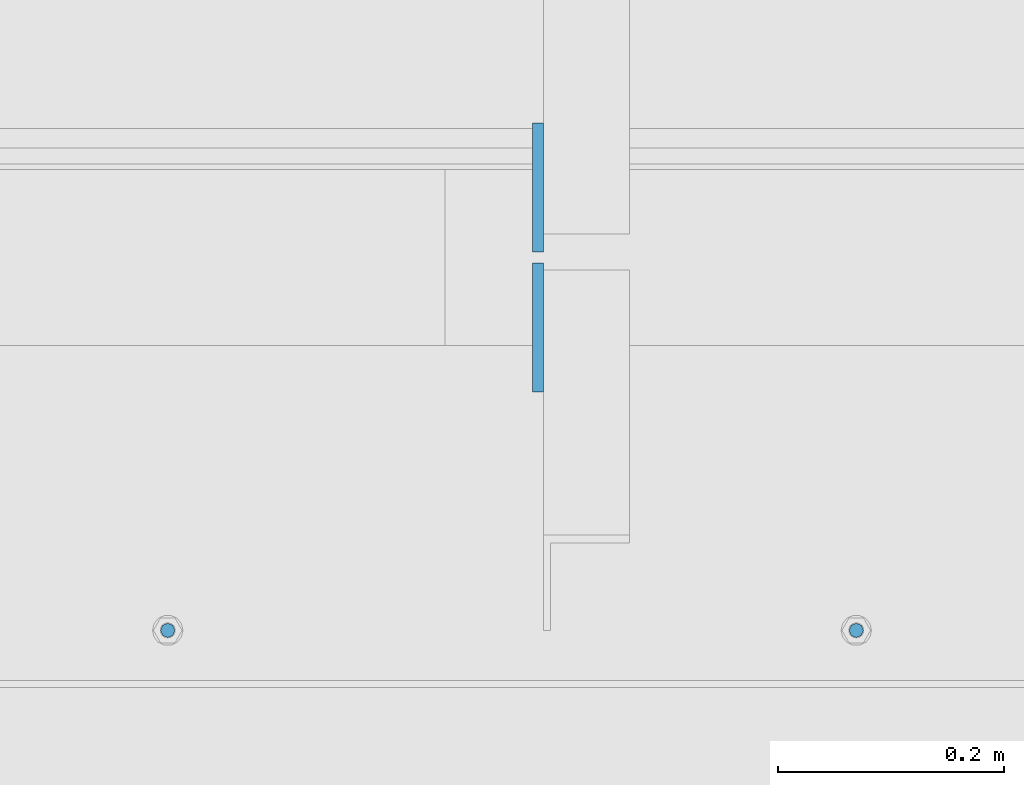
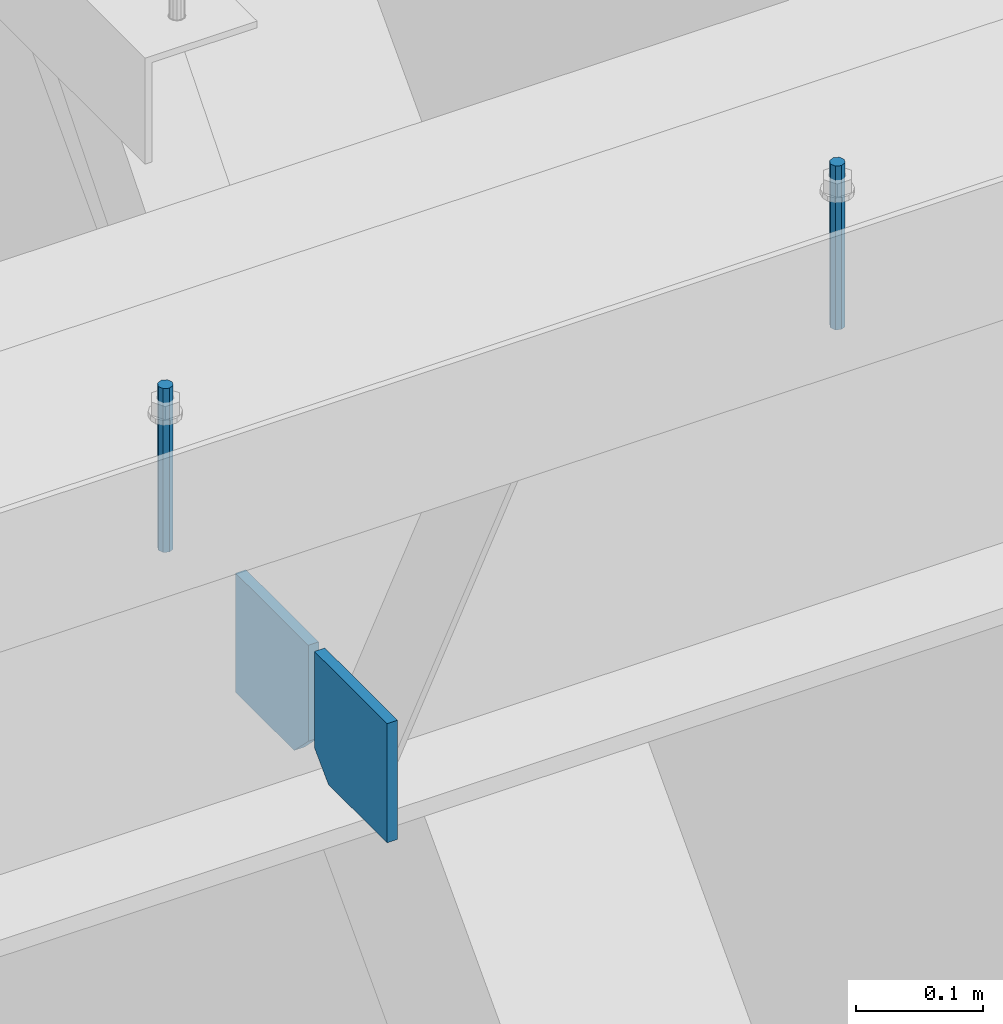
# One storey, part 465 of 1179: 4 columns, 1 element without a shape of its own.
"""IFC2X3 building model written with IfcOpenShell, lengths in millimetres."""

from ifc_helpers import new_model, si_unit, frame, origin_with_axes, place, context, subcontext, project, spatial, faceted_brep, material, type_object, element, aggregate, save


model = new_model("IFC2X3")

# Units and contexts
model_context = context("Model", 3, precision=1e-05, world=origin_with_axes())
body_context = subcontext(model_context, "Body", "Model", "MODEL_VIEW")
ifc_project = project(units=[si_unit("LENGTHUNIT", "METRE", prefix="MILLI"), si_unit("AREAUNIT", "SQUARE_METRE"), si_unit("VOLUMEUNIT", "CUBIC_METRE"), si_unit("MASSUNIT", "GRAM", prefix="KILO"), si_unit("TIMEUNIT", "SECOND"), si_unit("PLANEANGLEUNIT", "RADIAN"), si_unit("SOLIDANGLEUNIT", "STERADIAN"), si_unit("THERMODYNAMICTEMPERATUREUNIT", "DEGREE_CELSIUS"), si_unit("LUMINOUSINTENSITYUNIT", "LUMEN")], contexts=[model_context])

# Site, building, storey
site_placement = place(None, origin_with_axes())
site = spatial("IfcSite", under=ifc_project, at=site_placement, CompositionType="ELEMENT")
building_placement = place(site_placement, origin_with_axes())
building = spatial("IfcBuilding", under=site, at=building_placement, Name="Undefined", CompositionType="ELEMENT")
storey_placement = place(building_placement, origin_with_axes())
storey = spatial("IfcBuildingStorey", under=building, at=storey_placement, Name="Undefined", CompositionType="ELEMENT", Elevation=0.0)

# Assembly, columns
assembly_placement = place(storey_placement, origin_with_axes())
assembly = element("IfcElementAssembly", 1, at=assembly_placement, inside=storey, Name="BEAM", AssemblyPlace="NOTDEFINED", PredefinedType="RIGID_FRAME")
ifc_material_1 = material(Name="STEEL/A36")
column_type_1 = type_object("IfcColumnType", PredefinedType="NOTDEFINED")
column_1_placement = place(assembly_placement, frame((23069.5499995918, 27112.9125, 7496.175), z_axis=(0.0, -1.0, 0.0), x_axis=(0.0, 0.0, 1.0)))
column_1 = element("IfcColumn", 2, at=column_1_placement, type_object=column_type_1, material=ifc_material_1, Name="PLATE", context=body_context, shape_type="Brep", body=[
    faceted_brep([(22.2250000000004, 4.76250000000073, 57.1500000000015), (0.0, 4.76250000000073, 34.9249999999993), (0.0, -4.76250000000073, 34.9249999999993), (22.2250000000004, -4.76250000000073, 57.1500000000015), (114.300000000001, 4.76250000000073, 57.1500000000015), (114.300000000001, 4.76250000000073, -57.1500000000015), (0.0, 4.76250000000073, -57.1500000000015), (114.300000000001, -4.76250000000073, 57.1500000000015), (0.0, -4.76250000000073, -57.1500000000015), (114.300000000001, -4.76250000000073, -57.1500000000015)], [[[0, 1, 2, 3]], [[4, 5, 6, 1, 0]], [[7, 4, 0, 3]], [[8, 9, 7, 3, 2]], [[8, 6, 5, 9]], [[7, 9, 5, 4]], [[6, 8, 2, 1]]]),
])
column_2_placement = place(assembly_placement, frame((23069.5499995918, 26989.0875, 7496.175), z_axis=(0.0, 1.0, 0.0), x_axis=(0.0, 0.0, 1.0)))
column_2 = element("IfcColumn", 3, at=column_2_placement, type_object=column_type_1, material=ifc_material_1, Name="PLATE", context=body_context, shape_type="Brep", body=[
    faceted_brep([(22.2250000000004, 4.76250000000073, 57.1500000000015), (0.0, 4.76250000000073, 34.9249999999993), (0.0, -4.76250000000073, 34.9249999999993), (22.2250000000004, -4.76250000000073, 57.1500000000015), (114.300000000001, 4.76250000000073, 57.1500000000015), (114.300000000001, 4.76250000000073, -57.1500000000015), (0.0, 4.76250000000073, -57.1500000000015), (114.300000000001, -4.76250000000073, 57.1500000000015), (0.0, -4.76250000000073, -57.1500000000015), (114.300000000001, -4.76250000000073, -57.1500000000015)], [[[0, 1, 2, 3]], [[4, 5, 6, 1, 0]], [[7, 4, 0, 3]], [[8, 9, 7, 3, 2]], [[8, 6, 5, 9]], [[7, 9, 5, 4]], [[6, 8, 2, 1]]]),
])
ifc_material_2 = material(Name="STEEL/A307")
column_type_2 = type_object("IfcColumnType", PredefinedType="NOTDEFINED")
column_3_placement = place(assembly_placement, frame((23351.3315, 26720.8, 8020.05), z_axis=(0.0, 1.0, 0.0), x_axis=(0.0, 0.0, 1.0)))
column_3 = element("IfcColumn", 4, at=column_3_placement, type_object=column_type_2, material=ifc_material_2, Name="THREADED ROD", context=body_context, shape_type="Brep", body=[
    faceted_brep([(0.0, -6.34999999999854, 0.0), (0.0, -4.49012806053361, -4.49012806053452), (157.162499999999, -4.49012806053361, -4.49012806053361), (157.162499999999, -6.34999999999854, 0.0), (0.0, 0.0, -6.34999999999991), (157.162499999999, 0.0, -6.34999999999854), (0.0, 4.49012806053361, -4.49012806053452), (157.162499999999, 4.49012806053361, -4.49012806053361), (0.0, 6.34999999999854, 0.0), (157.162499999999, 6.34999999999854, 0.0), (0.0, 4.49012806053361, 4.49012806053452), (157.162499999999, 4.49012806053361, 4.49012806053361), (0.0, 0.0, 6.34999999999991), (157.162499999999, 0.0, 6.34999999999854), (0.0, -4.49012806053361, 4.49012806053452), (157.162499999999, -4.49012806053361, 4.49012806053361)], [[[0, 1, 2, 3]], [[1, 4, 5, 2]], [[4, 6, 7, 5]], [[6, 8, 9, 7]], [[8, 10, 11, 9]], [[10, 12, 13, 11]], [[12, 14, 15, 13]], [[14, 0, 3, 15]], [[5, 7, 9, 11, 13, 15, 3, 2]], [[14, 12, 10, 8, 6, 4, 1, 0]]]),
])
column_4_placement = place(assembly_placement, frame((22741.7315, 26720.8, 8020.05), z_axis=(0.0, 1.0, 0.0), x_axis=(0.0, 0.0, 1.0)))
column_4 = element("IfcColumn", 5, at=column_4_placement, type_object=column_type_2, material=ifc_material_2, Name="THREADED ROD", context=body_context, shape_type="Brep", body=[
    faceted_brep([(0.0, -6.34999999999854, 0.0), (0.0, -4.49012806053361, -4.49012806053452), (157.162499999999, -4.49012806053361, -4.49012806053361), (157.162499999999, -6.34999999999854, 0.0), (0.0, 0.0, -6.34999999999991), (157.162499999999, 0.0, -6.34999999999854), (0.0, 4.49012806053361, -4.49012806053452), (157.162499999999, 4.49012806053361, -4.49012806053361), (0.0, 6.34999999999854, 0.0), (157.162499999999, 6.34999999999854, 0.0), (0.0, 4.49012806053361, 4.49012806053452), (157.162499999999, 4.49012806053361, 4.49012806053361), (0.0, 0.0, 6.34999999999991), (157.162499999999, 0.0, 6.34999999999854), (0.0, -4.49012806053361, 4.49012806053452), (157.162499999999, -4.49012806053361, 4.49012806053361)], [[[0, 1, 2, 3]], [[1, 4, 5, 2]], [[4, 6, 7, 5]], [[6, 8, 9, 7]], [[8, 10, 11, 9]], [[10, 12, 13, 11]], [[12, 14, 15, 13]], [[14, 0, 3, 15]], [[5, 7, 9, 11, 13, 15, 3, 2]], [[14, 12, 10, 8, 6, 4, 1, 0]]]),
])
aggregate(assembly, [column_3, column_4, column_1, column_2])

save(model, "model.ifc")
